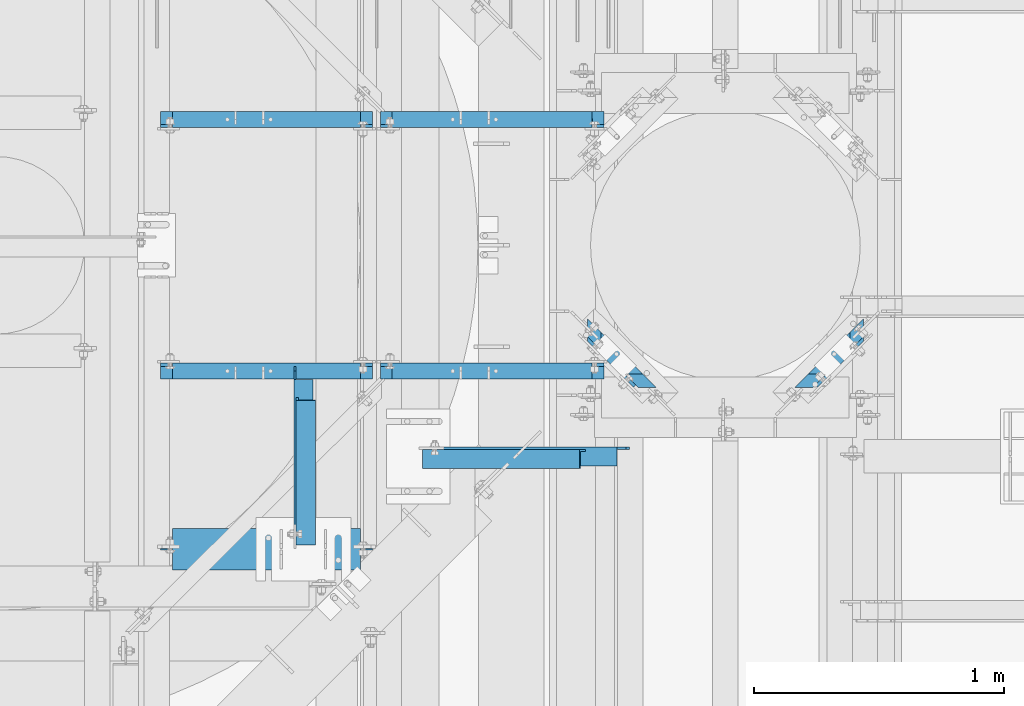
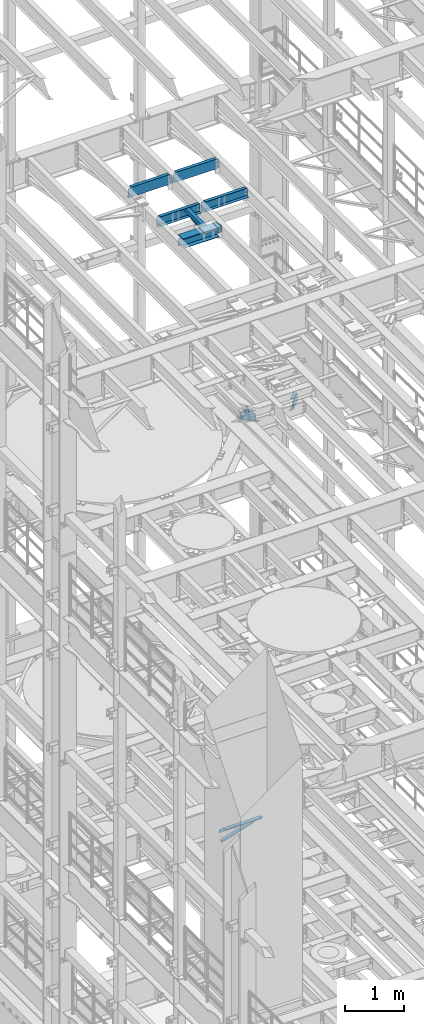
# One storey, part 1323 of 1876: 11 beams, 11 elements without a shape of their own.
"""IFC2X3 building model written with IfcOpenShell, lengths in millimetres."""

from ifc_helpers import new_model, si_unit, frame, origin_with_axes, place, context, subcontext, project, spatial, faceted_brep, material, type_object, element, aggregate, save


model = new_model("IFC2X3")

# Units and contexts
model_context = context("Model", 3, precision=1e-05, world=origin_with_axes())
body_context = subcontext(model_context, "Body", "Model", "MODEL_VIEW")
ifc_project = project(units=[si_unit("LENGTHUNIT", "METRE", prefix="MILLI"), si_unit("AREAUNIT", "SQUARE_METRE"), si_unit("VOLUMEUNIT", "CUBIC_METRE"), si_unit("MASSUNIT", "GRAM", prefix="KILO"), si_unit("TIMEUNIT", "SECOND"), si_unit("PLANEANGLEUNIT", "RADIAN"), si_unit("SOLIDANGLEUNIT", "STERADIAN"), si_unit("THERMODYNAMICTEMPERATUREUNIT", "DEGREE_CELSIUS"), si_unit("LUMINOUSINTENSITYUNIT", "LUMEN")], contexts=[model_context])

# Site, building, storey
site_placement = place(None, origin_with_axes())
site = spatial("IfcSite", under=ifc_project, at=site_placement, CompositionType="ELEMENT")
building_placement = place(site_placement, origin_with_axes())
building = spatial("IfcBuilding", under=site, at=building_placement, Name="Undefined", CompositionType="ELEMENT")
storey_placement = place(building_placement, origin_with_axes())
storey = spatial("IfcBuildingStorey", under=building, at=storey_placement, Name="Undefined", CompositionType="ELEMENT", Elevation=0.0)

# Assembly, beam
assembly_1_placement = place(storey_placement, origin_with_axes())
assembly_1 = element("IfcElementAssembly", 1, at=assembly_1_placement, inside=storey, Name="BEAM", AssemblyPlace="NOTDEFINED", PredefinedType="RIGID_FRAME")
ifc_material_1 = material(Name="STEEL/A992")
beam_type_1 = type_object("IfcBeamType", Name="W8X24", PredefinedType="NOTDEFINED")
beam_1_placement = place(assembly_1_placement, frame((3832.225, 10264.7762878418, 17883.1875), z_axis=(0.0, 0.0, 1.0), x_axis=(1.0, 0.0, 0.0)))
beam_1 = element("IfcBeam", 2, at=beam_1_placement, type_object=beam_type_1, material=ifc_material_1, Name="BEAM", ObjectType="W8X24", context=body_context, shape_type="Brep", body=[
    faceted_brep([(771.525000000001, -3.17499999999927, -90.4874999999993), (771.525000000001, -82.5499999999993, -90.4874999999993), (771.525000000001, -82.5499999999993, -100.012500000001), (771.525000000001, 82.5499999999993, -100.012500000001), (771.525000000001, 82.5499999999993, -90.4874999999993), (771.525000000001, 3.17499999999927, -90.4874999999993), (771.525000000001, 3.17499999999927, -87.3124998092608), (771.525000000001, -3.17499999999927, -87.3124998092608), (772.491729922589, 3.17499999999927, -82.4524202912144), (772.491729922589, -3.17499999999927, -82.4524202912144), (775.244743823067, 3.17499999999927, -78.3322438230607), (775.244743823067, -3.17499999999927, -78.3322438230607), (779.364920291221, 3.17499999999927, -75.5792299225832), (779.364920291221, -3.17499999999927, -75.5792299225832), (784.224999809267, 3.17499999999927, -74.6124999999956), (784.224999809267, -3.17499999999927, -74.6124999999956), (863.6, -3.17499999999927, -74.6124999999956), (863.6, 3.17499999999927, -74.6124999999956), (63.5000000000009, 82.5499999999993, 100.012500000001), (63.5000000000009, -82.5499999999993, 100.012500000001), (815.975000000001, -82.5499999999993, 100.012500000001), (815.975000000001, 82.5499999999993, 100.012500000001), (63.5000000000009, 82.5499999999993, 93.6624998092702), (63.5000000000009, -82.5499999999993, 93.6624998092702), (62.8684532715088, -82.5499999999993, 90.4874999999993), (816.606546728493, -82.5499999999993, 90.4874999999993), (815.975000000001, -82.5499999999993, 93.6624998092702), (815.975000000001, 82.5499999999993, 93.6624998092702), (62.8684532715088, 82.5499999999993, 90.4874999999993), (816.606546728493, 82.5499999999993, 90.4874999999993), (62.8684532715088, 3.17499999999927, 90.4874999999993), (816.606546728493, 3.17499999999927, 90.4874999999993), (107.949999999998, -3.17500000000018, -87.3124998092644), (107.949999999998, 3.17500000000018, -87.3124998092644), (107.950000000001, 3.17500000000018, -90.48749980926), (107.949999999998, 82.5500000000002, -90.4874999999993), (107.949999999998, 82.5500000000002, -100.012500000001), (107.949999999998, -82.5500000000002, -100.012500000001), (107.949999999998, -82.5500000000002, -90.4874999999993), (107.950000000001, -3.17500000000018, -90.48749980926), (106.98327007741, -3.17500000000018, -82.452420291218), (106.98327007741, 3.17500000000018, -82.452420291218), (104.230256176932, -3.17500000000018, -78.3322438230643), (104.230256176932, 3.17500000000018, -78.3322438230643), (100.110079708778, -3.17500000000018, -75.5792299225868), (100.110079708778, 3.17500000000018, -75.5792299225868), (95.2500001907329, -3.17500000000018, -74.6124999999993), (95.2500001907329, 3.17500000000018, -74.6124999999993), (15.8749999999982, -3.17500000000018, -74.6124999999993), (15.8749999999982, 3.17500000000018, -74.6124999999993), (15.875, -3.17499999999927, 80.9625000000051), (15.875, 3.17499999999927, 80.9625000000051), (50.8000001907358, -3.17499999999927, 80.9625000000051), (50.8000001907358, 3.17499999999927, 80.9625000000051), (55.6600797087813, -3.17499999999927, 81.9292299225926), (55.6600797087813, 3.17499999999927, 81.9292299225926), (59.7802561769349, -3.17499999999927, 84.6822438230702), (59.7802561769349, 3.17499999999927, 84.6822438230702), (62.5332700774129, -3.17499999999927, 88.8024202912238), (62.5332700774129, 3.17499999999927, 88.8024202912238), (62.8684532715088, -3.17499999999927, 90.4874999999993), (816.606546728493, -3.17499999999927, 90.4874999999993), (816.941729922589, -3.17499999999927, 88.8024202912238), (816.941729922589, 3.17499999999927, 88.8024202912238), (819.694743823067, -3.17499999999927, 84.6822438230702), (819.694743823067, 3.17499999999927, 84.6822438230702), (823.814920291221, -3.17499999999927, 81.9292299225926), (823.814920291221, 3.17499999999927, 81.9292299225926), (828.674999809266, -3.17499999999927, 80.9625000000051), (828.674999809266, 3.17499999999927, 80.9625000000051), (863.6, -3.17499999999927, 80.9625000000051), (863.6, 3.17499999999927, 80.9625000000051)], [[[0, 1, 2, 3, 4, 5, 6, 7]], [[7, 6, 8, 9]], [[9, 8, 10, 11]], [[11, 10, 12, 13]], [[13, 12, 14, 15]], [[16, 15, 14, 17]], [[18, 19, 20, 21]], [[19, 18, 22, 23]], [[20, 19, 23, 24, 25, 26]], [[20, 26, 27, 21]], [[28, 22, 18, 21, 27, 29]], [[30, 28, 29, 31]], [[32, 33, 34, 35, 36, 37, 38, 39]], [[40, 41, 33, 32]], [[42, 43, 41, 40]], [[44, 45, 43, 42]], [[46, 47, 45, 44]], [[48, 49, 47, 46]], [[50, 51, 49, 48]], [[52, 53, 51, 50]], [[54, 55, 53, 52]], [[56, 57, 55, 54]], [[58, 59, 57, 56]], [[23, 22, 28, 30, 59, 58, 60, 24]], [[24, 60, 61, 25]], [[62, 63, 31, 29, 27, 26, 25, 61]], [[64, 65, 63, 62]], [[66, 67, 65, 64]], [[68, 69, 67, 66]], [[70, 71, 69, 68]], [[71, 70, 16, 17]], [[12, 10, 8, 6, 5, 34, 33, 41, 43, 45, 47, 49, 51, 53, 55, 57, 59, 30, 31, 63, 65, 67, 69, 71, 17, 14]], [[35, 34, 5, 4]], [[36, 35, 4, 3]], [[37, 36, 3, 2]], [[38, 37, 2, 1]], [[39, 38, 1, 0]], [[70, 68, 66, 64, 62, 61, 60, 58, 56, 54, 52, 50, 48, 46, 44, 42, 40, 32, 39, 0, 7, 9, 11, 13, 15, 16]]]),
])
aggregate(assembly_1, [beam_1])

assembly_2_placement = place(storey_placement, origin_with_axes())
assembly_2 = element("IfcElementAssembly", 3, at=assembly_2_placement, inside=storey, AssemblyPlace="NOTDEFINED", PredefinedType="RIGID_FRAME")
ifc_material_2 = material(Name="STEEL/A36")
beam_type_2 = type_object("IfcBeamType", Name="L3X3X3/8", PredefinedType="NOTDEFINED")
beam_2_placement = place(assembly_2_placement, frame((4429.12348255626, 10270.4005098167, 17834.3924110517), z_axis=(1.0, 0.0, 0.0), x_axis=(1.02000002638406e-07, 0.989044329361461, 0.147618815053933)))
beam_2 = element("IfcBeam", 4, at=beam_2_placement, type_object=beam_type_2, material=ifc_material_2, ObjectType="L3X3X3/8", context=body_context, shape_type="Brep", body=[
    faceted_brep([(16.050927825192, 38.1000000000313, -38.1000000000104), (16.0509278349309, 38.1000000000931, 38.0999999999894), (602.226755217573, 38.1000000010426, 38.0999999998903), (602.226755207832, 38.100000000979, -38.1000000001095), (16.0509278349127, 28.5750000000844, 38.0999999999913), (602.226755217553, 28.5750000010321, 38.099999999893), (16.0509278263908, 28.5750000000298, -28.575000000008), (602.226755209031, 28.5750000009775, -28.5750000001062), (16.0509278262507, -38.1000000000367, -28.5749999999953), (602.226755208892, -38.0999999990909, -28.5750000000944), (16.0509278250356, -38.100000000044, -38.0999999999949), (602.226755207677, -38.0999999990963, -38.100000000094)], [[[0, 1, 2, 3]], [[1, 4, 5, 2]], [[4, 6, 7, 5]], [[6, 8, 9, 7]], [[8, 10, 11, 9]], [[10, 0, 3, 11]], [[5, 7, 9, 11, 3, 2]], [[10, 8, 6, 4, 1, 0]]]),
])
aggregate(assembly_2, [beam_2])

assembly_3_placement = place(storey_placement, origin_with_axes())
assembly_3 = element("IfcElementAssembly", 5, at=assembly_3_placement, inside=storey, Name="ANGLE", AssemblyPlace="NOTDEFINED", PredefinedType="RIGID_FRAME")
beam_3_placement = place(assembly_3_placement, frame((4419.59848197751, 10264.7762228332, 17945.1), z_axis=(1.0, 0.0, 0.0), x_axis=(0.0, 1.0, 0.0)))
beam_3 = element("IfcBeam", 6, at=beam_3_placement, type_object=beam_type_2, material=ifc_material_2, Name="ANGLE", ObjectType="L3X3X3/8", context=body_context, shape_type="Brep", body=[
    faceted_brep([(84.1370686928021, 28.5750001907327, 38.100000000024), (84.1370686928021, 38.0999999999985, 38.100000000024), (84.1370595487806, 38.0999999999985, -38.0999999999776), (84.1370595487806, 28.5750001907327, -38.0999999999776), (84.1370606917826, 28.5750000000007, -28.5749999999771), (15.8750613722059, 28.5750001907327, -38.0999999999958), (15.8750625152097, 28.5750000000007, -28.5749999999953), (3.17506156294075, 15.8750003814675, -38.0999999999995), (3.17506270594458, 15.8750003814675, -28.5749999999989), (3.17506156294075, 3.17500152587672, -38.0999999999995), (3.17506270594458, 3.17500152587672, -28.5749999999989), (3.17506108428279, -38.0999999999985, -38.0999999999995), (3.17506206535836, -38.0999999999985, -28.5749999999989), (731.83627583785, 9.52500095367213, -28.5749999997988), (712.786276600791, 28.5750000000007, -28.5749999998034), (679.449274800254, 28.5750000000007, -28.5749999998134), (731.836274223573, -38.0999999999985, -28.5749999997979), (731.83627583785, 3.17500152587672, -28.5749999997988), (679.449283401369, 28.5750000187982, 38.1000000001877), (679.449283401374, 38.0999999999985, 38.1000000001877), (679.449273571598, 38.0999999999985, -38.099999999813), (679.449273571521, 28.5750001907327, -38.099999999813), (712.786275372058, 28.5750001907327, -38.0999999998039), (731.836274609119, 9.52500095367213, -38.0999999997985), (731.836274609119, 3.17500152587672, -38.0999999997985), (731.836273242498, -38.0999999999985, -38.0999999997985)], [[[0, 1, 2, 3, 4]], [[4, 3, 5, 6]], [[6, 5, 7, 8]], [[8, 7, 9, 10]], [[9, 11, 12, 10]], [[13, 14, 15, 4, 6, 8, 10, 12, 16, 17]], [[0, 4, 15, 18]], [[1, 0, 18, 19]], [[2, 1, 19, 20]], [[18, 15, 21, 20, 19]], [[14, 22, 21, 15]], [[13, 23, 22, 14]], [[17, 24, 23, 13]], [[11, 9, 7, 5, 3, 2, 20, 21, 22, 23, 24, 25]], [[12, 11, 25, 16]], [[24, 17, 16, 25]]]),
])
aggregate(assembly_3, [beam_3])

assembly_4_placement = place(storey_placement, origin_with_axes())
assembly_4 = element("IfcElementAssembly", 7, at=assembly_4_placement, inside=storey, AssemblyPlace="NOTDEFINED", PredefinedType="RIGID_FRAME")
beam_4_placement = place(assembly_4_placement, frame((4879.97500015476, 10626.3831848175, 4870.44999999999), z_axis=(0.0, -1.0, 0.0), x_axis=(0.955933699062039, 0.0, 0.293582634019056)))
beam_4 = element("IfcBeam", 8, at=beam_4_placement, type_object=beam_type_2, material=ifc_material_2, ObjectType="L3X3X3/8", context=body_context, shape_type="Brep", body=[
    faceted_brep([(28.3079220453428, 38.1000000000076, -38.1000000000004), (28.3079220453428, 38.1000000000076, 38.1000000000004), (687.043110501988, 38.0999999999117, 38.1000000000004), (687.043110501988, 38.0999999999117, -38.1000000000004), (28.3079220453419, 28.5750000000044, 38.1000000000004), (687.043110501988, 28.5749999999093, 38.1000000000004), (28.3079220453419, 28.5750000000044, -28.5750000000007), (687.043110501988, 28.5749999999093, -28.5750000000007), (28.3079220453428, -38.1000000000158, -28.5750000000007), (687.043110501988, -38.1000000001113, -28.5750000000007), (28.3079220453428, -38.1000000000158, -38.1000000000004), (687.043110501988, -38.1000000001113, -38.1000000000004)], [[[0, 1, 2, 3]], [[1, 4, 5, 2]], [[4, 6, 7, 5]], [[6, 8, 9, 7]], [[8, 10, 11, 9]], [[10, 0, 3, 11]], [[5, 7, 9, 11, 3, 2]], [[10, 8, 6, 4, 1, 0]]]),
])
aggregate(assembly_4, [beam_4])

assembly_5_placement = place(storey_placement, origin_with_axes())
assembly_5 = element("IfcElementAssembly", 9, at=assembly_5_placement, inside=storey, Name="ANGLE", AssemblyPlace="NOTDEFINED", PredefinedType="RIGID_FRAME")
beam_5_placement = place(assembly_5_placement, frame((4879.97499983945, 10635.9081848175, 5092.7), z_axis=(0.0, -1.0, 0.0), x_axis=(1.0, 0.0, 0.0)))
beam_5 = element("IfcBeam", 10, at=beam_5_placement, type_object=beam_type_2, material=ifc_material_2, Name="ANGLE", ObjectType="L3X3X3/8", context=body_context, shape_type="Brep", body=[
    faceted_brep([(795.338000784122, 28.5749999999998, -28.5750000000007), (795.338002584359, 28.5749999999998, 38.1000000000004), (84.137014014791, 28.5749999999998, 38.1000000000258), (84.1370001605219, 28.5749999999998, -28.5750000000007), (795.338002584364, 38.1000000000004, 38.1000000000004), (84.1374011325761, 38.0999999999985, 38.0999999999776), (22.2249978717273, 28.5749999999998, -28.5750000000007), (22.2249978717273, 28.5750108587645, -38.1000000000004), (3.17499863466674, 9.52501162170302, -38.1000000000004), (3.17499863466674, 9.52501047870646, -28.5750000000007), (84.1370001605219, 28.5750108587645, -38.1000000000004), (84.137408980816, 38.0999999999985, -38.1000000000231), (795.338000527021, 38.1000000000004, -38.1000000000004), (795.338000526946, 28.5750001907354, -38.1000000000004), (831.850002775394, 28.5749999999998, -28.5750000000007), (831.850002518217, 28.5750001907354, -38.1000000000004), (844.55000258466, 15.8750003814703, -28.5750000000007), (844.550002327483, 15.8750003814703, -38.1000000000004), (844.55000258466, 3.17500152587945, -28.5750000000007), (844.550002327483, 3.17500152587945, -38.1000000000004), (844.550000160548, -38.1000000000004, -28.5750000000007), (844.550000160548, -38.1000000000004, -38.1000000000004), (3.17499999075153, -38.0999999999985, -28.5749999999998), (3.17499999075153, -38.0999999999985, -38.0999999999999), (3.17500012894925, 3.17500152587672, -38.0999999999999), (3.17500032897624, 3.17500152587672, -28.5749999999998)], [[[0, 1, 2, 3]], [[1, 4, 5, 2]], [[6, 7, 8, 9]], [[3, 10, 7, 6]], [[2, 5, 11, 10, 3]], [[4, 12, 11, 5]], [[1, 0, 13, 12, 4]], [[14, 15, 13, 0]], [[16, 17, 15, 14]], [[18, 19, 17, 16]], [[19, 18, 20, 21]], [[21, 20, 22, 23]], [[8, 7, 10, 11, 12, 13, 15, 17, 19, 21, 23, 24]], [[9, 8, 24, 25]], [[20, 18, 16, 14, 0, 3, 6, 9, 25, 22]], [[24, 23, 22, 25]]]),
])
aggregate(assembly_5, [beam_5])

assembly_6_placement = place(storey_placement, origin_with_axes())
assembly_6 = element("IfcElementAssembly", 11, at=assembly_6_placement, inside=storey, Name="BEAM", AssemblyPlace="NOTDEFINED", PredefinedType="RIGID_FRAME")
beam_type_3 = type_object("IfcBeamType", Name="C8X18.75", PredefinedType="NOTDEFINED")
beam_6_placement = place(assembly_6_placement, frame((6385.88998469733, 10866.6484550167, 13208.0), z_axis=(0.0, 0.0, -1.0), x_axis=(0.707106781186548, 0.707106781186547, 0.0)))
beam_6 = element("IfcBeam", 12, at=beam_6_placement, type_object=beam_type_3, material=ifc_material_2, Name="BEAM", ObjectType="C8X18.75", context=body_context, shape_type="Brep", body=[
    faceted_brep([(154.855381656382, 31.7500000000059, -69.8500000000004), (142.155381656381, 19.0500000000043, -69.8500000000004), (96.4837187575304, 19.0500000000043, -69.8500000000004), (96.4837187574976, 31.750000000005, -69.8500000000004), (161.728572025017, 31.750000000005, -70.8167299225879), (149.028572025016, 19.0500000000034, -70.8167299225879), (167.55538146565, 31.7500000000068, -73.5697438230654), (154.85538146565, 19.0500000000043, -73.5697438230654), (171.448731061109, 31.750000000005, -77.6899202912191), (158.748731061109, 19.0500000000034, -77.6899202912191), (172.815893628787, 31.7500000000059, -82.5499998092655), (160.115893628785, 19.0500000000034, -82.5499998092655), (172.815893628785, 31.7500000000068, -101.6), (109.315893628776, -31.750000000005, -101.6), (109.315893628776, -31.750000000005, -97.3645500000002), (160.115893628785, 19.0500000000034, -88.9012700000003), (370.226446820196, 19.0500000000034, 88.9012700000003), (421.026446820204, -31.750000000005, 97.3645500000002), (32.9837187574867, -31.750000000005, 97.3645500000002), (83.7837187574951, 19.0500000000034, 88.9012700000003), (96.4837187575304, 19.0500000000043, 88.9012700000003), (344.694271950037, -31.750000000005, -97.3645500000002), (344.694271950037, -31.750000000005, -101.6), (281.194271950028, 31.750000000005, -101.6), (281.194271950028, 31.750000000005, -82.5499998092655), (293.894271950028, 19.0500000000043, -82.5499998092655), (293.894271950028, 19.0500000000043, -88.9012700000003), (282.561434517702, 31.7500000000059, -77.6899202912191), (295.261434517704, 19.0500000000034, -77.6899202912191), (286.454784113161, 31.7500000000059, -73.5697438230654), (299.154784113163, 19.0500000000034, -73.5697438230654), (292.281593553796, 31.750000000005, -70.8167299225879), (304.981593553797, 19.0500000000043, -70.8167299225879), (299.154783922431, 31.750000000005, -69.8500000000004), (311.854783922432, 19.0500000000034, -69.8500000000004), (370.226446820196, 19.0500000000034, -69.8500000000004), (357.526446820193, 31.7500000000059, -69.8500000000004), (357.526446820193, 31.7500000000059, 101.6), (421.026446820204, -31.750000000005, 101.6), (32.9837187574867, -31.750000000005, 101.6), (83.783718948247, 19.0500001907553, 101.6), (96.4837187575304, 19.0500001907444, 101.6), (96.4837187574976, 31.750000000005, 101.6)], [[[0, 1, 2, 3]], [[4, 5, 1, 0]], [[6, 7, 5, 4]], [[8, 9, 7, 6]], [[10, 11, 9, 8]], [[12, 13, 14, 15, 11, 10]], [[16, 17, 18, 19, 20]], [[21, 22, 23, 24, 25, 26]], [[25, 24, 27, 28]], [[28, 27, 29, 30]], [[30, 29, 31, 32]], [[32, 31, 33, 34]], [[35, 34, 33, 36]], [[37, 38, 17, 16, 35, 36]], [[39, 18, 17, 38]], [[18, 39, 40, 19]], [[41, 20, 19, 40]], [[39, 38, 37, 42, 41, 40]], [[20, 41, 42, 3, 2]], [[26, 25, 28, 30, 32, 34, 35, 16, 20, 2, 1, 5, 7, 9, 11, 15]], [[21, 26, 15, 14]], [[22, 21, 14, 13]], [[23, 22, 13, 12]], [[6, 4, 0, 3, 42, 37, 36, 33, 31, 29, 27, 24, 23, 12, 10, 8]]]),
])
aggregate(assembly_6, [beam_6])

assembly_7_placement = place(storey_placement, origin_with_axes())
assembly_7 = element("IfcElementAssembly", 13, at=assembly_7_placement, inside=storey, Name="BEAM", AssemblyPlace="NOTDEFINED", PredefinedType="RIGID_FRAME")
beam_7_placement = place(assembly_7_placement, frame((5572.35064030268, 11125.8078300167, 13208.0), z_axis=(0.0, 0.0, -1.0), x_axis=(0.707106781186547, -0.707106781186548, 0.0)))
beam_7 = element("IfcBeam", 14, at=beam_7_placement, type_object=beam_type_3, material=ifc_material_2, Name="BEAM", ObjectType="C8X18.75", context=body_context, shape_type="Brep", body=[
    faceted_brep([(67.3519190196753, 31.7500000000055, -69.8500000000004), (54.6519190196727, 19.0500000000029, -69.8500000000004), (-3.71974387894079, 19.0500000000029, -69.8500000000004), (8.98025612106085, 31.7500000000055, -69.8500000000004), (74.2251093883087, 31.7500000000055, -70.8167299225879), (61.5251093883062, 19.0500000000029, -70.8167299225879), (80.0519188289445, 31.7500000000055, -73.5697438230654), (67.351918828942, 19.0500000000029, -73.5697438230654), (83.9452684244034, 31.7500000000055, -77.6899202912191), (71.2452684244008, 19.0500000000029, -77.6899202912191), (85.3124309920795, 31.7500000000055, -82.5499998092655), (72.612430992077, 19.0500000000029, -82.5499998092655), (85.3124309920795, 31.7500000000055, -101.6), (21.8124309920686, -31.7500000000055, -101.6), (21.8124309920686, -31.7500000000055, -97.3645500000002), (72.612430992077, 19.0500000000029, -88.9012700000003), (333.522984183766, -31.7500000000073, 101.6), (333.522984183766, -31.7500000000073, 97.3645500000002), (282.722984183757, 19.0500000000029, 88.9012700000003), (282.722983993118, 19.050000190744, 101.6), (-54.5197438789492, -31.7500000000055, 101.6), (-54.5197438789492, -31.7500000000055, 97.3645500000002), (-3.71974387894079, 19.0500000000029, 88.9012700000003), (270.022984183847, 19.0500000000029, 88.9012700000003), (257.190809313624, -31.7500000000055, -97.3645500000002), (257.190809313624, -31.7500000000055, -101.6), (193.690809313613, 31.7500000000055, -101.6), (193.690809313613, 31.7500000000055, -82.5499998092655), (206.390809313616, 19.0500000000029, -82.5499998092655), (206.390809313616, 19.0500000000029, -88.9012700000003), (195.057971881289, 31.7500000000055, -77.6899202912191), (207.757971881291, 19.0500000000029, -77.6899202912191), (198.951321476748, 31.7500000000055, -73.5697438230654), (211.65132147675, 19.0500000000029, -73.5697438230654), (204.778130917384, 31.7500000000055, -70.8167299225879), (217.478130917387, 19.0500000000029, -70.8167299225879), (211.651321286017, 31.7500000000036, -69.8500000000004), (224.351321286019, 19.0500000000029, -69.8500000000004), (270.022984183847, 19.0500000000029, -69.8500000000004), (270.022984183755, 31.7500000000036, -69.8500000000004), (270.022984183755, 31.7500000000036, 101.6), (270.022984183847, 19.050000190744, 101.6), (8.98025612106085, 31.7500000000055, 101.6)], [[[0, 1, 2, 3]], [[4, 5, 1, 0]], [[6, 7, 5, 4]], [[8, 9, 7, 6]], [[10, 11, 9, 8]], [[12, 13, 14, 15, 11, 10]], [[16, 17, 18, 19]], [[20, 21, 17, 16]], [[17, 21, 22, 23, 18]], [[24, 25, 26, 27, 28, 29]], [[28, 27, 30, 31]], [[31, 30, 32, 33]], [[33, 32, 34, 35]], [[35, 34, 36, 37]], [[38, 37, 36, 39]], [[40, 41, 23, 38, 39]], [[19, 18, 23, 41]], [[40, 42, 20, 16, 19, 41]], [[22, 21, 20, 42, 3, 2]], [[29, 28, 31, 33, 35, 37, 38, 23, 22, 2, 1, 5, 7, 9, 11, 15]], [[24, 29, 15, 14]], [[25, 24, 14, 13]], [[26, 25, 13, 12]], [[6, 4, 0, 3, 42, 40, 39, 36, 34, 32, 30, 27, 26, 12, 10, 8]]]),
])
aggregate(assembly_7, [beam_7])

assembly_8_placement = place(storey_placement, origin_with_axes())
assembly_8 = element("IfcElementAssembly", 15, at=assembly_8_placement, inside=storey, Name="BEAM", AssemblyPlace="NOTDEFINED", PredefinedType="RIGID_FRAME")
beam_8_placement = place(assembly_8_placement, frame((4711.7, 10977.5629999161, 17881.6), z_axis=(0.0, 0.0, 1.0), x_axis=(1.0, 0.0, 0.0)))
beam_8 = element("IfcBeam", 16, at=beam_8_placement, type_object=beam_type_3, material=ifc_material_2, Name="BEAM", ObjectType="C8X18.75", context=body_context, shape_type="Brep", body=[
    faceted_brep([(863.600000000001, -31.75, 101.599999999999), (863.600000000001, -31.75, 97.3645499999984), (863.600000000001, -19.0576219043487, 95.2499998092644), (863.600000000001, 31.75, 95.2499998092644), (863.600000000001, 31.75, 101.599999999999), (864.566729922589, 10.1145240623118, 90.389920291218), (864.566729922589, 31.75, 90.389920291218), (867.319743823067, 19.0499999999993, 86.2697438230643), (867.319743823067, 31.75, 86.2697438230643), (865.561414246514, 19.0499999999993, 88.9012699999985), (871.439920291221, 19.0499999999993, 83.5167299225868), (871.439920291221, 31.75, 83.5167299225868), (876.299999809266, 19.0499999999993, 82.5499999999993), (876.299999809266, 31.75, 82.5499999999993), (911.225, 19.0499999999993, 82.5499999999993), (911.225, 31.75, 82.5499999999993), (63.5, -31.75, 101.599999999999), (63.5, 31.75, 101.599999999999), (63.5, 31.75, 95.2499998092717), (63.5, -19.0576219043924, 95.2499998092717), (63.5, -31.75, 97.3645499999984), (62.5332700774125, 31.75, 90.3899202912253), (62.5332700774125, 10.1145240622682, 90.3899202912253), (59.780256176934, 31.75, 86.2697438230716), (59.780256176934, 19.0499999999993, 86.2697438230716), (61.538585753482, 19.0499999999993, 88.9012699999985), (55.6600797087804, 31.75, 83.5167299225941), (55.6600797087804, 19.0499999999993, 83.5167299225941), (50.8000001907349, 31.75, 82.5500000000065), (50.8000001907349, 19.0499999999993, 82.5500000000065), (15.875, 31.75, 82.5500000000065), (15.875, 19.0499999999993, 82.5500000000065), (15.875, 31.75, -101.599999999999), (15.875, -31.75, -101.599999999999), (15.875, -31.75, -97.3645499999984), (15.875, 19.0499999999993, -88.9012699999985), (911.225, 31.75, -101.599999999999), (911.225, -31.75, -101.599999999999), (911.225, -31.75, -97.3645499999984), (911.225, 19.0499999999993, -88.9012699999985)], [[[0, 1, 2, 3, 4]], [[5, 6, 3, 2]], [[7, 8, 6, 5, 9]], [[10, 11, 8, 7]], [[12, 13, 11, 10]], [[14, 15, 13, 12]], [[16, 17, 18, 19, 20]], [[19, 18, 21, 22]], [[22, 21, 23, 24, 25]], [[24, 23, 26, 27]], [[27, 26, 28, 29]], [[29, 28, 30, 31]], [[32, 33, 34, 35, 31, 30]], [[33, 32, 36, 37]], [[34, 33, 37, 38]], [[35, 34, 38, 39]], [[10, 7, 9, 25, 24, 27, 29, 31, 35, 39, 14, 12]], [[2, 1, 20, 19, 22, 25, 9, 5]], [[16, 20, 1, 0]], [[17, 16, 0, 4]], [[36, 32, 30, 28, 26, 23, 21, 18, 17, 4, 3, 6, 8, 11, 13, 15]], [[39, 38, 37, 36, 15, 14]]]),
])
aggregate(assembly_8, [beam_8])

assembly_9_placement = place(storey_placement, origin_with_axes())
assembly_9 = element("IfcElementAssembly", 17, at=assembly_9_placement, inside=storey, Name="BEAM", AssemblyPlace="NOTDEFINED", PredefinedType="RIGID_FRAME")
beam_9_placement = place(assembly_9_placement, frame((4711.70000000318, 11984.0374996678, 17881.6), z_axis=(0.0, 0.0, -1.0), x_axis=(1.0, 0.0, 0.0)))
beam_9 = element("IfcBeam", 18, at=beam_9_placement, type_object=beam_type_3, material=ifc_material_2, Name="BEAM", ObjectType="C8X18.75", context=body_context, shape_type="Brep", body=[
    faceted_brep([(863.599999996826, -31.75, -97.3645499999984), (863.599999996826, -31.75, -101.599999999999), (863.599999996826, 31.75, -101.599999999999), (863.599999996826, 31.75, -95.2499998092644), (863.599999996826, -19.0576219043487, -95.2499998092644), (864.566729919414, 31.75, -90.389920291218), (864.566729919414, 10.1145240623118, -90.389920291218), (865.561414243339, 19.0499999999993, -88.9012699999985), (867.319743819892, 31.75, -86.2697438230643), (867.319743819892, 19.0499999999993, -86.2697438230643), (871.439920288046, 31.75, -83.5167299225868), (871.439920288046, 19.0499999999993, -83.5167299225868), (876.299999806091, 31.75, -82.5499999999993), (876.299999806091, 19.0499999999993, -82.5499999999993), (911.224999996825, 19.0499999999993, -82.5499999999993), (911.224999996825, 31.75, -82.5499999999993), (15.8749999999991, -31.75, 101.599999999999), (15.8749999999991, -31.75, 97.3645499999984), (911.224999996825, -31.75, 97.3645499999984), (911.224999996825, -31.75, 101.599999999999), (15.8749999999991, 31.75, 101.599999999999), (911.224999996825, 31.75, 101.599999999999), (63.499999996825, -19.0576219043924, -95.2499998092717), (63.499999996825, 31.75, -95.2499998092717), (63.499999996825, 31.75, -101.599999999999), (63.499999996825, -31.75, -101.599999999999), (63.499999996825, -31.75, -97.3645499999984), (62.5332700742374, 10.1145240622682, -90.3899202912253), (62.5332700742374, 31.75, -90.3899202912253), (61.538585750307, 19.0499999999993, -88.9012699999985), (59.780256173759, 19.0499999999993, -86.2697438230716), (59.780256173759, 31.75, -86.2697438230716), (55.6600797056053, 19.0499999999993, -83.5167299225941), (55.6600797056053, 31.75, -83.5167299225941), (50.8000001875598, 19.0499999999993, -82.5500000000065), (50.8000001875598, 31.75, -82.5500000000065), (15.8749999999991, 19.0500000000002, -82.5499999999993), (15.8749999999991, 31.75, -82.5499999999993), (15.8749999999991, 19.0500000000002, 88.9012699999985), (911.224999996825, 19.0499999999993, 88.9012699999985)], [[[0, 1, 2, 3, 4]], [[4, 3, 5, 6]], [[7, 6, 5, 8, 9]], [[9, 8, 10, 11]], [[11, 10, 12, 13]], [[14, 13, 12, 15]], [[16, 17, 18, 19]], [[20, 16, 19, 21]], [[22, 23, 24, 25, 26]], [[27, 28, 23, 22]], [[29, 30, 31, 28, 27]], [[32, 33, 31, 30]], [[34, 35, 33, 32]], [[36, 37, 35, 34]], [[38, 17, 16, 20, 37, 36]], [[17, 38, 39, 18]], [[21, 19, 18, 39, 14, 15]], [[10, 8, 5, 3, 2, 24, 23, 28, 31, 33, 35, 37, 20, 21, 15, 12]], [[25, 24, 2, 1]], [[26, 25, 1, 0]], [[29, 27, 22, 26, 0, 4, 6, 7]], [[39, 38, 36, 34, 32, 30, 29, 7, 9, 11, 13, 14]]]),
])
aggregate(assembly_9, [beam_9])

assembly_10_placement = place(storey_placement, origin_with_axes())
assembly_10 = element("IfcElementAssembly", 19, at=assembly_10_placement, inside=storey, Name="BEAM", AssemblyPlace="NOTDEFINED", PredefinedType="RIGID_FRAME")
beam_10_placement = place(assembly_10_placement, frame((3784.6, 10977.5625, 17881.6), z_axis=(0.0, 0.0, 1.0), x_axis=(1.0, 0.0, 0.0)))
beam_10 = element("IfcBeam", 20, at=beam_10_placement, type_object=beam_type_3, material=ifc_material_2, Name="BEAM", ObjectType="C8X18.75", context=body_context, shape_type="Brep", body=[
    faceted_brep([(863.600000000001, -31.75, 101.599999999999), (863.600000000001, -31.75, 97.3645499999984), (863.600000000001, -19.0576219043487, 95.2499998092644), (863.600000000001, 31.75, 95.2499998092644), (863.600000000001, 31.75, 101.599999999999), (864.566729922589, 10.1145240623118, 90.389920291218), (864.566729922589, 31.75, 90.389920291218), (867.319743823067, 19.0499999999993, 86.2697438230643), (867.319743823067, 31.75, 86.2697438230643), (865.561414246514, 19.0499999999993, 88.9012699999985), (871.439920291221, 19.0499999999993, 83.5167299225868), (871.439920291221, 31.75, 83.5167299225868), (876.299999809266, 19.0499999999993, 82.5499999999993), (876.299999809266, 31.75, 82.5499999999993), (911.225, 19.0499999999993, 82.5499999999993), (911.225, 31.75, 82.5499999999993), (111.125, -31.75, 101.599999999999), (111.125, 31.75, 101.599999999999), (111.125, 31.75, 95.2499998092717), (111.125, -19.0576219043924, 95.2499998092717), (111.125, -31.75, 97.3645499999984), (110.158270077412, 31.75, 90.3899202912253), (110.158270077412, 10.1145240622682, 90.3899202912253), (107.405256176934, 31.75, 86.2697438230716), (107.405256176934, 19.0499999999993, 86.2697438230716), (109.163585753482, 19.0499999999993, 88.9012699999985), (103.28507970878, 31.75, 83.5167299225941), (103.28507970878, 19.0499999999993, 83.5167299225941), (98.4250001907349, 31.75, 82.5500000000065), (98.4250001907349, 19.0499999999993, 82.5500000000065), (63.4999999999995, 31.75, 82.5500000000065), (63.4999999999995, 19.0499999999993, 82.5500000000065), (63.499999996825, 31.75, -101.599999999999), (63.499999996825, -31.75, -101.599999999999), (63.499999996825, -31.75, -97.3645499999984), (63.4999999999995, 19.0499999999993, -88.9012699999985), (911.225, 31.75, -101.599999999999), (911.225, -31.75, -101.599999999999), (911.225, -31.75, -97.3645499999984), (911.225, 19.0499999999993, -88.9012699999985)], [[[0, 1, 2, 3, 4]], [[5, 6, 3, 2]], [[7, 8, 6, 5, 9]], [[10, 11, 8, 7]], [[12, 13, 11, 10]], [[14, 15, 13, 12]], [[16, 17, 18, 19, 20]], [[19, 18, 21, 22]], [[22, 21, 23, 24, 25]], [[24, 23, 26, 27]], [[27, 26, 28, 29]], [[29, 28, 30, 31]], [[32, 33, 34, 35, 31, 30]], [[33, 32, 36, 37]], [[34, 33, 37, 38]], [[35, 34, 38, 39]], [[10, 7, 9, 25, 24, 27, 29, 31, 35, 39, 14, 12]], [[2, 1, 20, 19, 22, 25, 9, 5]], [[16, 20, 1, 0]], [[17, 16, 0, 4]], [[36, 32, 30, 28, 26, 23, 21, 18, 17, 4, 3, 6, 8, 11, 13, 15]], [[39, 38, 37, 36, 15, 14]]]),
])
aggregate(assembly_10, [beam_10])

assembly_11_placement = place(storey_placement, origin_with_axes())
assembly_11 = element("IfcElementAssembly", 21, at=assembly_11_placement, inside=storey, Name="BEAM", AssemblyPlace="NOTDEFINED", PredefinedType="RIGID_FRAME")
beam_11_placement = place(assembly_11_placement, frame((3784.6, 11984.0375, 17881.6), z_axis=(0.0, 0.0, -1.0), x_axis=(1.0, 0.0, 0.0)))
beam_11 = element("IfcBeam", 22, at=beam_11_placement, type_object=beam_type_3, material=ifc_material_2, Name="BEAM", ObjectType="C8X18.75", context=body_context, shape_type="Brep", body=[
    faceted_brep([(863.599999996826, -31.75, -97.3645499999984), (863.599999996826, -31.75, -101.599999999999), (863.599999996826, 31.75, -101.599999999999), (863.599999996826, 31.75, -95.2499998092644), (863.599999996826, -19.0576219043487, -95.2499998092644), (864.566729919414, 31.75, -90.389920291218), (864.566729919414, 10.1145240623118, -90.389920291218), (865.561414243339, 19.0499999999993, -88.9012699999985), (867.319743819892, 31.75, -86.2697438230643), (867.319743819892, 19.0499999999993, -86.2697438230643), (871.439920288046, 31.75, -83.5167299225868), (871.439920288046, 19.0499999999993, -83.5167299225868), (876.299999806091, 31.75, -82.5499999999993), (876.299999806091, 19.0499999999993, -82.5499999999993), (911.224999996825, 19.0499999999993, -82.5499999999993), (911.224999996825, 31.75, -82.5499999999993), (63.5, -31.75, 101.599999999999), (63.5, -31.75, 97.3645499999984), (911.224999996825, -31.75, 97.3645499999984), (911.224999996825, -31.75, 101.599999999999), (63.5, 31.75, 101.599999999999), (911.224999996825, 31.75, 101.599999999999), (111.125000000001, -19.0576219043924, -95.2499998092717), (111.125000000001, 31.75, -95.2499998092717), (111.125000000001, 31.75, -101.599999999999), (111.125000000001, -31.75, -101.599999999999), (111.125000000001, -31.75, -97.3645499999984), (110.158270077413, 10.1145240622682, -90.3899202912253), (110.158270077413, 31.75, -90.3899202912253), (109.163585753483, 19.0499999999993, -88.9012699999985), (107.405256176935, 19.0499999999993, -86.2697438230716), (107.405256176935, 31.75, -86.2697438230716), (103.285079708781, 19.0499999999993, -83.5167299225941), (103.285079708781, 31.75, -83.5167299225941), (98.4250001907358, 19.0499999999993, -82.5500000000065), (98.4250001907358, 31.75, -82.5500000000065), (63.5000000000005, 19.0499999999993, -82.5500000000065), (63.5000000000005, 31.75, -82.5500000000065), (63.5000000000005, 19.0499999999993, 88.9012699999985), (911.224999996825, 19.0499999999993, 88.9012699999985)], [[[0, 1, 2, 3, 4]], [[4, 3, 5, 6]], [[7, 6, 5, 8, 9]], [[9, 8, 10, 11]], [[11, 10, 12, 13]], [[14, 13, 12, 15]], [[16, 17, 18, 19]], [[20, 16, 19, 21]], [[22, 23, 24, 25, 26]], [[27, 28, 23, 22]], [[29, 30, 31, 28, 27]], [[32, 33, 31, 30]], [[34, 35, 33, 32]], [[36, 37, 35, 34]], [[38, 17, 16, 20, 37, 36]], [[17, 38, 39, 18]], [[21, 19, 18, 39, 14, 15]], [[10, 8, 5, 3, 2, 24, 23, 28, 31, 33, 35, 37, 20, 21, 15, 12]], [[25, 24, 2, 1]], [[26, 25, 1, 0]], [[29, 27, 22, 26, 0, 4, 6, 7]], [[39, 38, 36, 34, 32, 30, 29, 7, 9, 11, 13, 14]]]),
])
aggregate(assembly_11, [beam_11])

save(model, "model.ifc")
